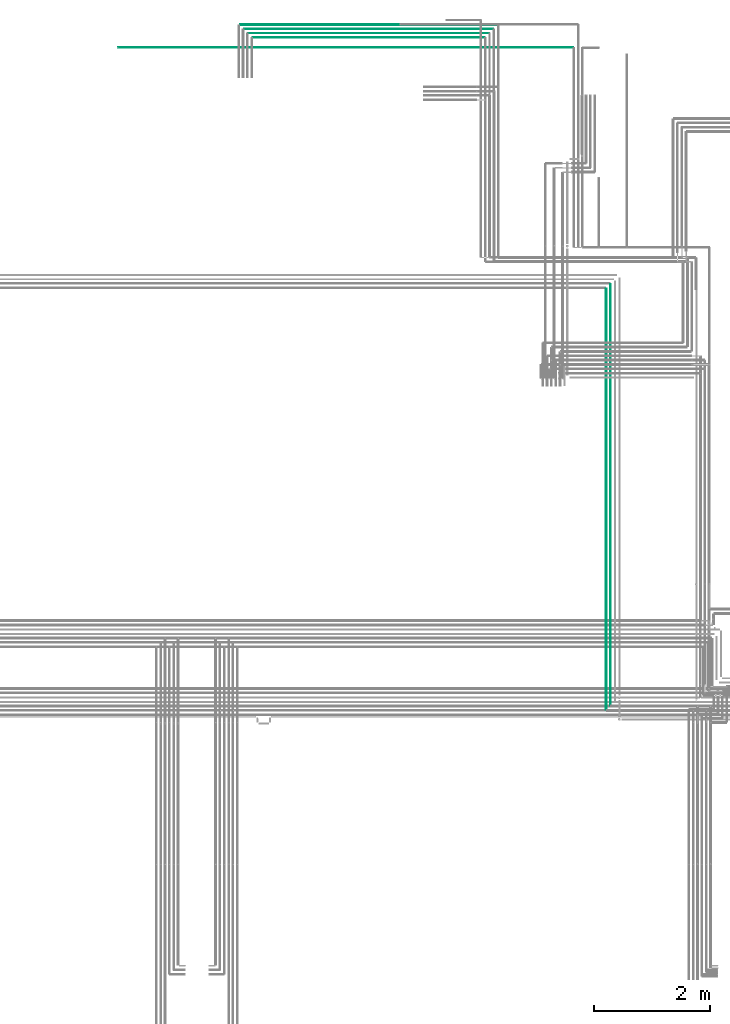
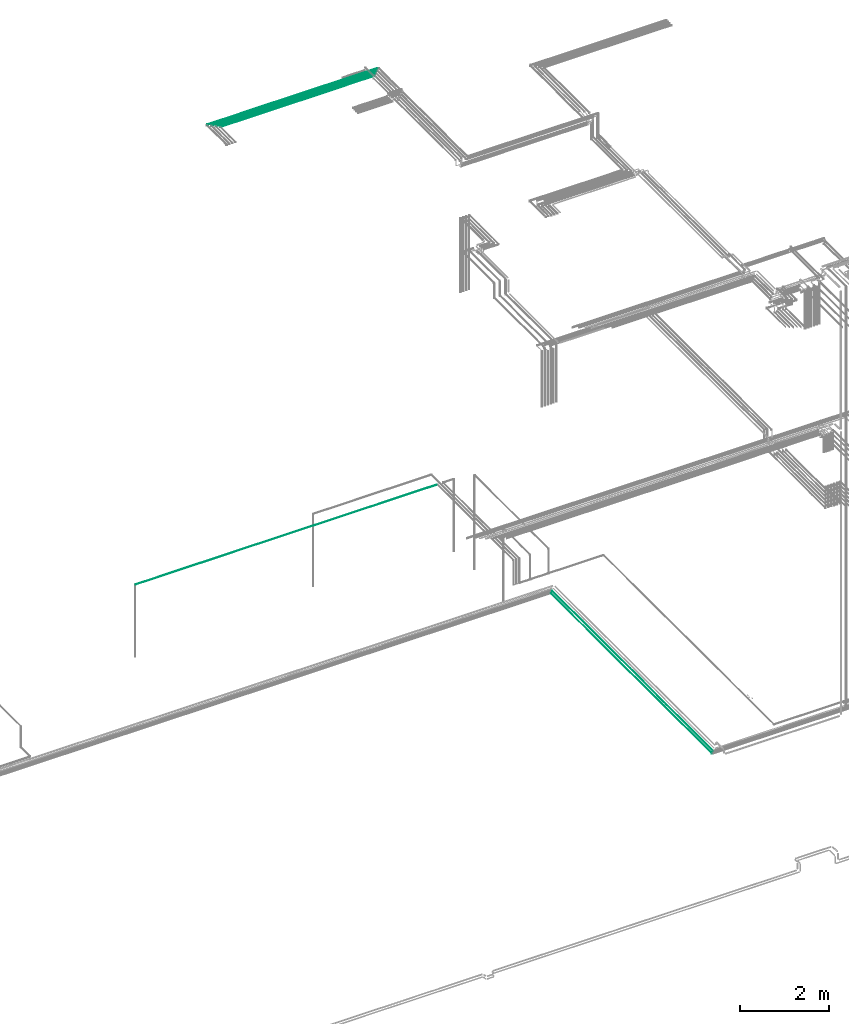
# One storey, part 108 of 331: 7 flow segments.
"""IFC2X3 building model written with IfcOpenShell, lengths in millimetres."""

from ifc_helpers import new_model, entity, si_unit, converted_unit, derived_unit, direction, frame, frame_2d, origin, origin_2d_with_axis, place, context, subcontext, project, spatial, circle, extrude, type_object, element, save


model = new_model("IFC2X3")

# Units and contexts
model_context = context("Model", 3, precision=0.01, world=origin(), true_north=direction((6.12303176911189e-17, 1.0)))
body_context = subcontext(model_context, "Body", "Model", "MODEL_VIEW")
ifc_project = project(units=[si_unit("LENGTHUNIT", "METRE", prefix="MILLI"), si_unit("AREAUNIT", "SQUARE_METRE"), si_unit("VOLUMEUNIT", "CUBIC_METRE"), converted_unit("PLANEANGLEUNIT", "DEGREE", entity("IfcRatioMeasure", 0.0174532925199433), si_unit("PLANEANGLEUNIT", "RADIAN"), dimensions=[0, 0, 0, 0, 0, 0, 0]), si_unit("MASSUNIT", "GRAM", prefix="KILO"), derived_unit("MASSDENSITYUNIT", [(si_unit("MASSUNIT", "GRAM", prefix="KILO"), 1), (si_unit("LENGTHUNIT", "METRE"), -3)]), derived_unit("MOMENTOFINERTIAUNIT", [(si_unit("LENGTHUNIT", "METRE"), 4)]), si_unit("TIMEUNIT", "SECOND"), si_unit("FREQUENCYUNIT", "HERTZ"), si_unit("THERMODYNAMICTEMPERATUREUNIT", "DEGREE_CELSIUS"), derived_unit("THERMALTRANSMITTANCEUNIT", [(si_unit("MASSUNIT", "GRAM", prefix="KILO"), 1), (si_unit("THERMODYNAMICTEMPERATUREUNIT", "KELVIN"), -1), (si_unit("TIMEUNIT", "SECOND"), -3)]), derived_unit("VOLUMETRICFLOWRATEUNIT", [(si_unit("LENGTHUNIT", "METRE"), 3), (si_unit("TIMEUNIT", "SECOND"), -1)]), derived_unit("MASSFLOWRATEUNIT", [(si_unit("MASSUNIT", "GRAM", prefix="KILO"), 1), (si_unit("TIMEUNIT", "SECOND"), -1)]), derived_unit("ROTATIONALFREQUENCYUNIT", [(si_unit("TIMEUNIT", "SECOND"), -1)]), si_unit("ELECTRICCURRENTUNIT", "AMPERE"), si_unit("ELECTRICVOLTAGEUNIT", "VOLT"), si_unit("POWERUNIT", "WATT"), si_unit("FORCEUNIT", "NEWTON", prefix="KILO"), si_unit("ILLUMINANCEUNIT", "LUX"), si_unit("LUMINOUSFLUXUNIT", "LUMEN"), si_unit("LUMINOUSINTENSITYUNIT", "CANDELA"), derived_unit("USERDEFINED", [(si_unit("MASSUNIT", "GRAM", prefix="KILO"), -1), (si_unit("LENGTHUNIT", "METRE"), -2), (si_unit("TIMEUNIT", "SECOND"), 3), (si_unit("LUMINOUSFLUXUNIT", "LUMEN"), 1)]), derived_unit("LINEARVELOCITYUNIT", [(si_unit("LENGTHUNIT", "METRE"), 1), (si_unit("TIMEUNIT", "SECOND"), -1)]), si_unit("PRESSUREUNIT", "PASCAL"), derived_unit("USERDEFINED", [(si_unit("LENGTHUNIT", "METRE"), -2), (si_unit("MASSUNIT", "GRAM", prefix="KILO"), 1), (si_unit("TIMEUNIT", "SECOND"), -2)]), derived_unit("LINEARFORCEUNIT", [(si_unit("MASSUNIT", "GRAM", prefix="KILO"), 1), (si_unit("LENGTHUNIT", "METRE"), 1), (si_unit("TIMEUNIT", "SECOND"), -2), (si_unit("LENGTHUNIT", "METRE"), -1)]), derived_unit("PLANARFORCEUNIT", [(si_unit("MASSUNIT", "GRAM", prefix="KILO"), 1), (si_unit("LENGTHUNIT", "METRE"), 1), (si_unit("TIMEUNIT", "SECOND"), -2), (si_unit("LENGTHUNIT", "METRE"), -2)])], contexts=[model_context])

# Site, building, storey
site_placement = place(None, frame((0.0, -0.00077364408347762, 0.0)))
site = spatial("IfcSite", under=ifc_project, at=site_placement, CompositionType="ELEMENT")
building_placement = place(site_placement, origin())
building = spatial("IfcBuilding", under=site, at=building_placement, CompositionType="ELEMENT")
storey_placement = place(building_placement, origin())
storey = spatial("IfcBuildingStorey", under=building, at=storey_placement, CompositionType="ELEMENT", Elevation=0.0)

# Flow segments
pipe_segment_type = type_object("IfcPipeSegmentType", PredefinedType="NOTDEFINED")
flow_segment_1_placement = place(building_placement, frame((60432.4014929007, 8311.9877045678, 6667.40472776404)))
element("IfcFlowSegment", 1, at=flow_segment_1_placement, inside=storey, type_object=pipe_segment_type, context=body_context, shape_type="SweptSolid", body=[
    extrude(circle(Radius=6.0, at=frame_2d((0.0, -1.08286712929839e-12), x_axis=(1.0, 0.0))), frame((7.59527223591454, 0.0, 7.59527223591454), z_axis=(0.0, 1.0, 0.0), x_axis=(1.0, 0.0, 0.0)), (0.0, 0.0, 1.0), 7273.99696563513),
])
flow_segment_2_placement = place(building_placement, frame((60507.4014929007, 8386.98770456778, 6667.40472776404)))
element("IfcFlowSegment", 2, at=flow_segment_2_placement, inside=storey, type_object=pipe_segment_type, context=body_context, shape_type="SweptSolid", body=[
    extrude(circle(Radius=6.0, at=origin_2d_with_axis()), frame((7.59527223591454, 0.0, 7.59527223591562), z_axis=(0.0, 1.0, 0.0), x_axis=(1.0, 0.0, 0.0)), (0.0, 0.0, 1.0), 7273.99696563514),
])
flow_segment_3_placement = place(storey_placement, frame((52013.6241529943, 19744.4055014083, 7344.4047277641)))
element("IfcFlowSegment", 3, at=flow_segment_3_placement, inside=storey, type_object=pipe_segment_type, context=body_context, shape_type="SweptSolid", body=[
    extrude(circle(Radius=4.0, at=frame_2d((0.0, 1.08286712929839e-12), x_axis=(1.0, 0.0))), frame((0.0, 5.59527223591499, 5.59527223591716), z_axis=(1.0, 0.0, 0.0), x_axis=(0.0, -1.0, 0.0)), (0.0, 0.0, 1.0), 7859.80841472954),
])
flow_segment_4_placement = place(building_placement, frame((54112.9985196319, 20140.9039541202, 19040.9047277641)))
element("IfcFlowSegment", 4, at=flow_segment_4_placement, inside=storey, type_object=pipe_segment_type, context=body_context, shape_type="SweptSolid", body=[
    extrude(circle(Radius=7.5, at=frame_2d((4.33146851719357e-12, 0.0), x_axis=(1.0, 0.0))), frame((0.0, 9.09527223592719, 9.09527223591636), z_axis=(1.0, 0.0, 0.0), x_axis=(0.0, 1.0, 0.0)), (0.0, 0.0, 1.0), 4446.1915189337),
])
flow_segment_5_placement = place(building_placement, frame((54183.9985196319, 20067.4039541202, 19042.4047277641)))
element("IfcFlowSegment", 5, at=flow_segment_5_placement, inside=storey, type_object=pipe_segment_type, context=body_context, shape_type="SweptSolid", body=[
    extrude(circle(Radius=6.0, at=frame_2d((0.0, -2.16573425859679e-12), x_axis=(1.0, 0.0))), frame((0.0, 7.59527223591454, 7.59527223591887), z_axis=(1.0, 0.0, 0.0), x_axis=(0.0, 1.0, 0.0)), (0.0, 0.0, 1.0), 4304.19151893371),
])
flow_segment_6_placement = place(building_placement, frame((54254.9985196319, 19994.4039541202, 19044.4047277641)))
element("IfcFlowSegment", 6, at=flow_segment_6_placement, inside=storey, type_object=pipe_segment_type, context=body_context, shape_type="SweptSolid", body=[
    extrude(circle(Radius=4.0, at=origin_2d_with_axis()), frame((0.0, 5.59527223591499, 5.59527223591499), z_axis=(1.0, 0.0, 0.0), x_axis=(0.0, 1.0, 0.0)), (0.0, 0.0, 1.0), 4162.19151893371),
])
flow_segment_7_placement = place(building_placement, frame((54329.9985196319, 19919.4039541202, 19044.4047277641)))
element("IfcFlowSegment", 7, at=flow_segment_7_placement, inside=storey, type_object=pipe_segment_type, context=body_context, shape_type="SweptSolid", body=[
    extrude(circle(Radius=4.0, at=origin_2d_with_axis()), frame((0.0, 5.59527223591499, 5.59527223591499), z_axis=(1.0, 0.0, 0.0), x_axis=(0.0, 1.0, 0.0)), (0.0, 0.0, 1.0), 4012.19151893374),
])

save(model, "model.ifc")
